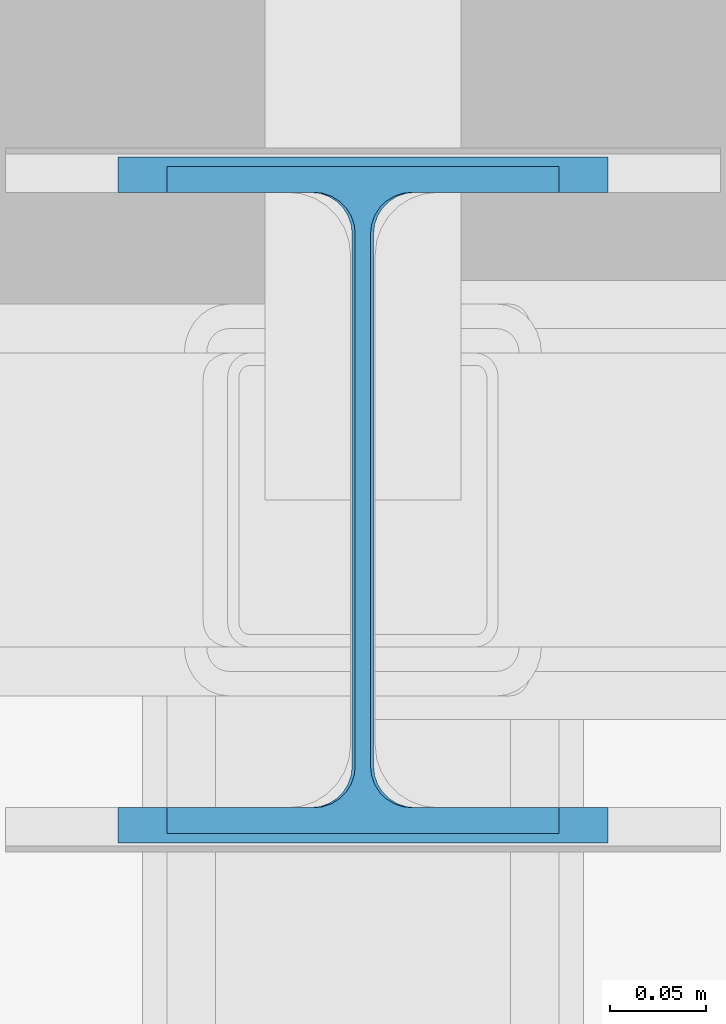
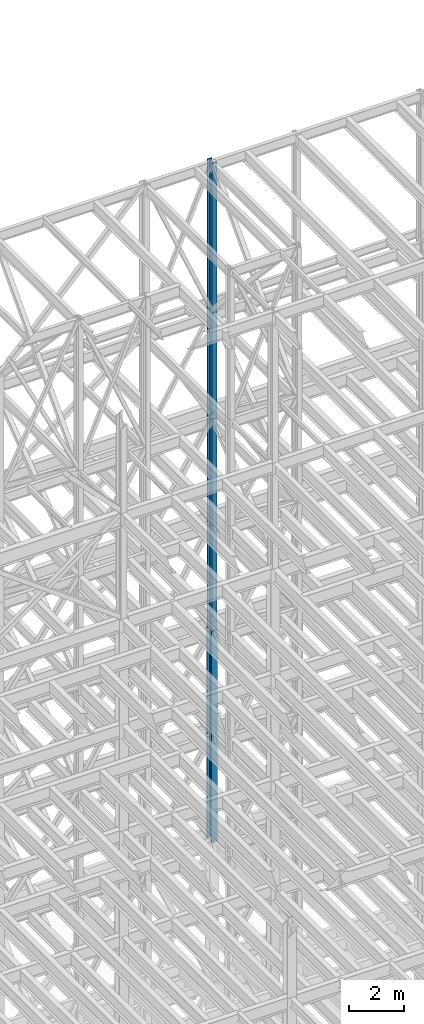
# One storey, part 98 of 150: 3 columns.
"""IFC2X3 building model written with IfcOpenShell, lengths in millimetres."""

from ifc_helpers import new_model, si_unit, frame, origin_with_axes, origin_2d_with_axis, place, context, subcontext, project, spatial, i_section, extrude, material, type_object, element, save


model = new_model("IFC2X3")

# Units and contexts
model_context = context("Model", 3, precision=1e-05, world=origin_with_axes())
body_context = subcontext(model_context, "Body", "Model", "MODEL_VIEW")
ifc_project = project(units=[si_unit("LENGTHUNIT", "METRE", prefix="MILLI"), si_unit("AREAUNIT", "SQUARE_METRE"), si_unit("VOLUMEUNIT", "CUBIC_METRE"), si_unit("MASSUNIT", "GRAM", prefix="KILO"), si_unit("TIMEUNIT", "SECOND"), si_unit("PLANEANGLEUNIT", "RADIAN"), si_unit("SOLIDANGLEUNIT", "STERADIAN"), si_unit("THERMODYNAMICTEMPERATUREUNIT", "DEGREE_CELSIUS"), si_unit("LUMINOUSINTENSITYUNIT", "LUMEN")], contexts=[model_context])

# Site, building, storey
site_placement = place(None, origin_with_axes())
site = spatial("IfcSite", under=ifc_project, at=site_placement, CompositionType="ELEMENT")
building_placement = place(site_placement, origin_with_axes())
building = spatial("IfcBuilding", under=site, at=building_placement, Name="Undefined", CompositionType="ELEMENT")
storey_placement = place(building_placement, origin_with_axes())
storey = spatial("IfcBuildingStorey", under=building, at=storey_placement, Name="Undefined", CompositionType="ELEMENT", Elevation=0.0)

# Columns
ifc_material = material(Name="STEEL/A992")
column_type_1 = type_object("IfcColumnType", Name="W14X43", PredefinedType="NOTDEFINED")
column_1_placement = place(storey_placement, frame((65836.8, 31877.0, 54483.001143), z_axis=(0.0, 0.0, 1.0), x_axis=(1.0, 0.0, 0.0)))
element("IfcColumn", 1, at=column_1_placement, inside=storey, type_object=column_type_1, material=ifc_material, Name="COLUMN", ObjectType="W14X43", context=body_context, shape_type="SweptSolid", body=[
    extrude(i_section(OverallWidth=203.2, OverallDepth=346.075, WebThickness=7.9375, FlangeThickness=13.462, FilletRadius=21.4629, at=origin_2d_with_axis()), frame((0.0, 0.0, 11430.0), z_axis=(0.0, 0.0, -1.0), x_axis=(-1.0, 0.0, 0.0)), (0.0, 0.0, 1.0), 11430.0),
])
column_2_placement = place(storey_placement, frame((65836.8, 31877.0, 45034.201143), z_axis=(0.0, 0.0, 1.0), x_axis=(1.0, 0.0, 0.0)))
element("IfcColumn", 2, at=column_2_placement, inside=storey, type_object=column_type_1, material=ifc_material, Name="COLUMN", ObjectType="W14X43", context=body_context, shape_type="SweptSolid", body=[
    extrude(i_section(OverallWidth=203.2, OverallDepth=346.075, WebThickness=7.9375, FlangeThickness=13.462, FilletRadius=21.4629, at=origin_2d_with_axis()), frame((0.0, 0.0, 9448.8), z_axis=(0.0, 0.0, -1.0), x_axis=(-1.0, 0.0, 0.0)), (0.0, 0.0, 1.0), 9448.8),
])
column_type_2 = type_object("IfcColumnType", Name="W14X68", PredefinedType="NOTDEFINED")
column_3_placement = place(storey_placement, frame((65836.8, 31877.0, 35585.401143), z_axis=(0.0, 0.0, 1.0), x_axis=(1.0, 0.0, 0.0)))
element("IfcColumn", 3, at=column_3_placement, inside=storey, type_object=column_type_2, material=ifc_material, Name="COLUMN", ObjectType="W14X68", context=body_context, shape_type="SweptSolid", body=[
    extrude(i_section(OverallWidth=254.0, OverallDepth=355.6, WebThickness=11.1125, FlangeThickness=18.288, FilletRadius=21.3994, at=origin_2d_with_axis()), frame((0.0, 0.0, 9448.8), z_axis=(0.0, 0.0, -1.0), x_axis=(-1.0, 0.0, 0.0)), (0.0, 0.0, 1.0), 9448.8),
])

save(model, "model.ifc")
